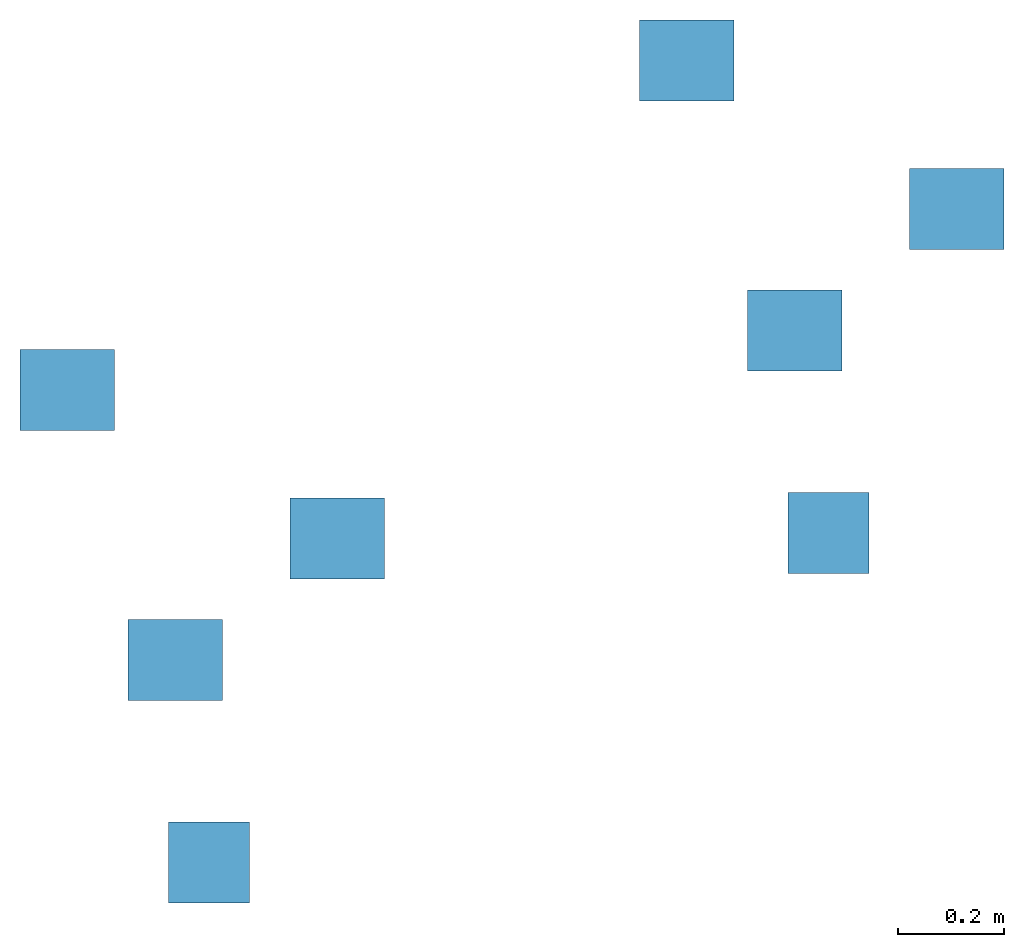
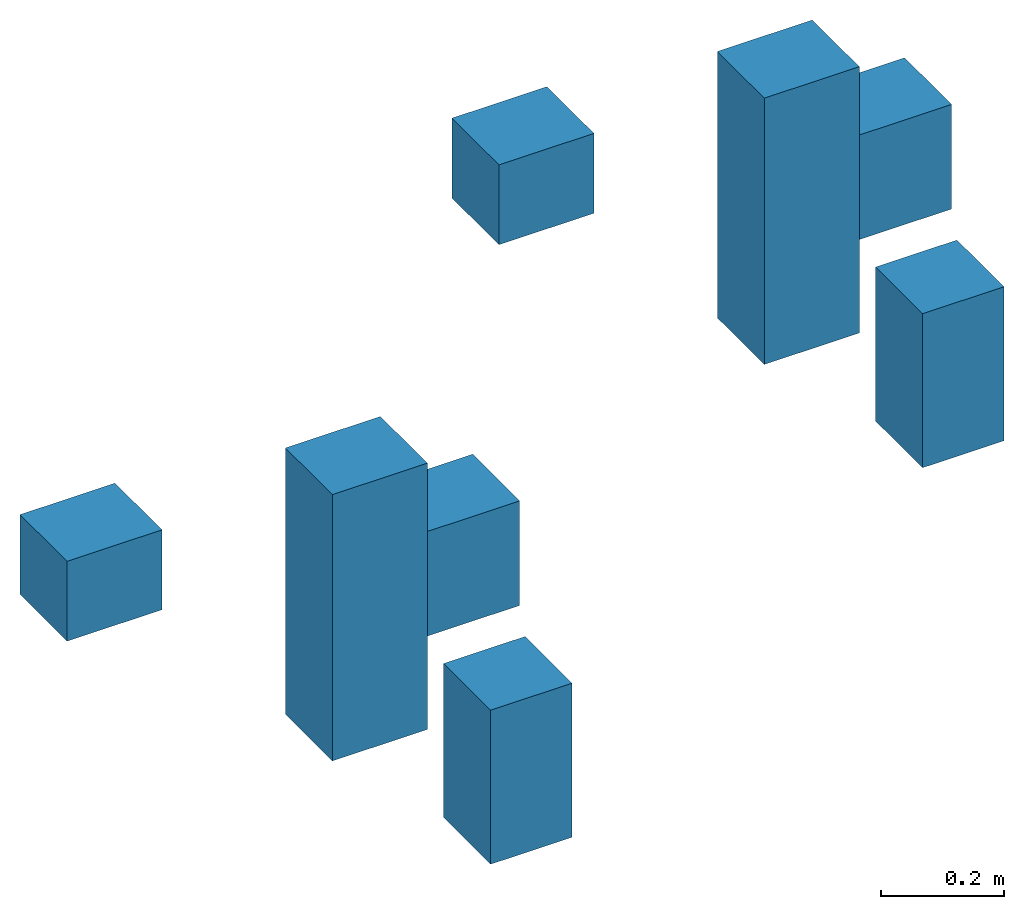
# One storey: 2 columns.
"""IFC2X3 building model written with IfcOpenShell, lengths in feet."""

from ifc_helpers import new_model, entity, si_unit, converted_unit, derived_unit, direction, frame, frame_2d, origin, origin_2d_with_axis, place, context, subcontext, project, spatial, rectangle, extrude, source, transform, mapped, type_object, type_shapes, element, save


model = new_model("IFC2X3")

# Units and contexts
model_context = context("Model", 3, precision=0.0001, world=origin(), true_north=direction((6.12303176911189e-17, 1.0)))
body_context = subcontext(model_context, "Body", "Model", "MODEL_VIEW")
ifc_project = project(units=[converted_unit("LENGTHUNIT", "FOOT", entity("IfcRatioMeasure", 0.3048), si_unit("LENGTHUNIT", "METRE"), dimensions=[1, 0, 0, 0, 0, 0, 0]), converted_unit("AREAUNIT", "SQUARE FOOT", entity("IfcRatioMeasure", 0.09290304), si_unit("AREAUNIT", "SQUARE_METRE"), dimensions=[2, 0, 0, 0, 0, 0, 0]), converted_unit("VOLUMEUNIT", "CUBIC FOOT", entity("IfcRatioMeasure", 0.028316846592), si_unit("VOLUMEUNIT", "CUBIC_METRE"), dimensions=[3, 0, 0, 0, 0, 0, 0]), converted_unit("PLANEANGLEUNIT", "DEGREE", entity("IfcRatioMeasure", 0.0174532925199433), si_unit("PLANEANGLEUNIT", "RADIAN"), dimensions=[0, 0, 0, 0, 0, 0, 0]), si_unit("MASSUNIT", "GRAM", prefix="KILO"), derived_unit("MASSDENSITYUNIT", [(si_unit("MASSUNIT", "GRAM", prefix="KILO"), 1), (si_unit("LENGTHUNIT", "METRE"), -3)]), si_unit("TIMEUNIT", "SECOND"), si_unit("FREQUENCYUNIT", "HERTZ"), si_unit("THERMODYNAMICTEMPERATUREUNIT", "DEGREE_CELSIUS"), derived_unit("THERMALTRANSMITTANCEUNIT", [(si_unit("MASSUNIT", "GRAM", prefix="KILO"), 1), (si_unit("THERMODYNAMICTEMPERATUREUNIT", "KELVIN"), -1), (si_unit("TIMEUNIT", "SECOND"), -3)]), derived_unit("VOLUMETRICFLOWRATEUNIT", [(si_unit("LENGTHUNIT", "METRE"), 3), (si_unit("TIMEUNIT", "SECOND"), -1)]), si_unit("ELECTRICCURRENTUNIT", "AMPERE"), si_unit("ELECTRICVOLTAGEUNIT", "VOLT"), si_unit("POWERUNIT", "WATT"), si_unit("FORCEUNIT", "NEWTON"), si_unit("ILLUMINANCEUNIT", "LUX"), si_unit("LUMINOUSFLUXUNIT", "LUMEN"), si_unit("LUMINOUSINTENSITYUNIT", "CANDELA"), derived_unit("USERDEFINED", [(si_unit("MASSUNIT", "GRAM", prefix="KILO"), -1), (si_unit("LENGTHUNIT", "METRE"), -2), (si_unit("TIMEUNIT", "SECOND"), 3), (si_unit("LUMINOUSFLUXUNIT", "LUMEN"), 1)]), derived_unit("LINEARVELOCITYUNIT", [(si_unit("LENGTHUNIT", "METRE"), 1), (si_unit("TIMEUNIT", "SECOND"), -1)]), si_unit("PRESSUREUNIT", "PASCAL"), derived_unit("USERDEFINED", [(si_unit("LENGTHUNIT", "METRE"), -2), (si_unit("MASSUNIT", "GRAM", prefix="KILO"), 1), (si_unit("TIMEUNIT", "SECOND"), -2)])], contexts=[model_context])

# Site, building, storey
site_placement = place(None, origin())
site = spatial("IfcSite", under=ifc_project, at=site_placement, CompositionType="ELEMENT")
building_placement = place(site_placement, origin())
building = spatial("IfcBuilding", under=site, at=building_placement, CompositionType="ELEMENT")
storey_placement = place(building_placement, origin())
storey = spatial("IfcBuildingStorey", under=building, at=storey_placement, Name="Level 1", CompositionType="ELEMENT", Elevation=0.0)

# Columns
column_type = type_object("IfcColumnType", Name="Family_Instance", PredefinedType="COLUMN")
shared_shape = source(origin(), body_context, "Body", "SweptSolid", [
    extrude(rectangle(XDim=0.5, YDim=0.583333333333333, at=origin_2d_with_axis()), frame((-0.217099891684259, 3.42066933568414, 0.0), z_axis=(0.0, 0.0, 1.0), x_axis=(0.0, -1.0, 0.0)), (0.0, 0.0, 1.0), 0.518397962176874),
    extrude(rectangle(XDim=0.5, YDim=0.583333333333333, at=frame_2d((0.0, 1.11022302462516e-16), x_axis=(1.0, 0.0))), frame((1.44956677498241, 2.50400266901747, 0.0), z_axis=(0.0, 0.0, 1.0), x_axis=(0.0, -1.0, 0.0)), (0.0, 0.0, 1.0), 0.678671602325006),
    extrude(rectangle(XDim=0.5, YDim=0.583333333333333, at=origin_2d_with_axis()), frame((0.449566774982407, 1.75400266901747, 0.0), z_axis=(0.0, 0.0, 1.0), x_axis=(0.0, -1.0, 0.0)), (0.0, 0.0, 1.0), 1.72849390032968),
    extrude(rectangle(XDim=0.5, YDim=0.499999999999999, at=frame_2d((0.0, 8.32667268468867e-17), x_axis=(1.0, 0.0))), frame((0.65790010831574, 0.504002669017472, 0.0), z_axis=(0.0, 0.0, 1.0), x_axis=(0.0, -1.0, 0.0)), (0.0, 0.0, 1.0), 1.0),
])
type_shapes(column_type, [shared_shape])
for number, where, name in (
    (1, (1.08333333333334, -1.41666666666667, 0.0), "Family:Family_Instance"),
    (2, (4.90943956905536, 0.617710105405517, 0.0), "Family:Family_Instance"),
):
    element("IfcColumn", number, at=place(storey_placement, frame(where)), inside=storey, type_object=column_type, Name=name, ObjectType="Family_Instance", context=body_context, shape_type="MappedRepresentation", body=[
        mapped(shared_shape, transform((0.0, 0.0, 0.0), scale=1.0)),
    ])

save(model, "model.ifc")
